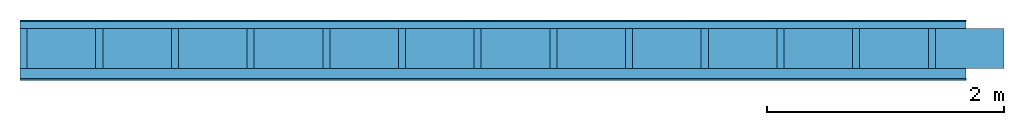
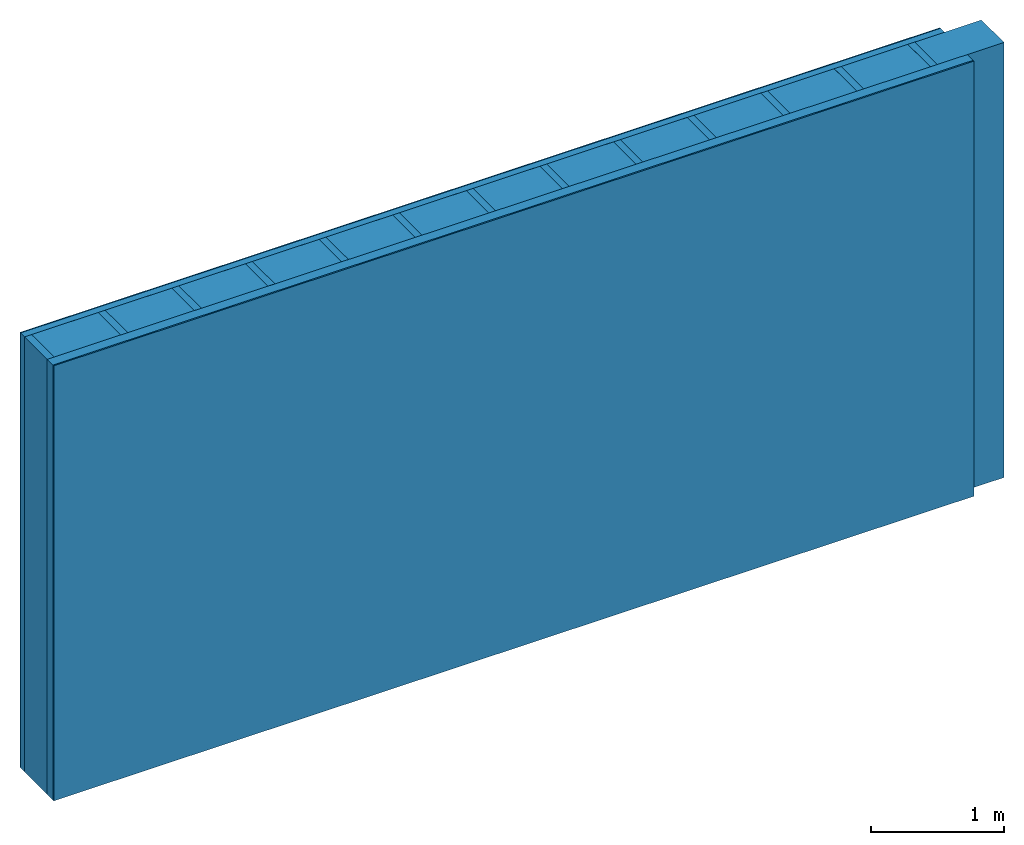
# One storey: 4 plates, 2 members, 1 element without a shape of its own.
"""IFC4 building model written with IfcOpenShell, lengths in metres."""

from ifc_helpers import new_model, si_unit, derived_unit, direction, frame, frame_2d, origin, origin_with_axes, place, context, project, spatial, rectangle, extrude, material, layer, layer_set, type_object, element, aggregate, save


model = new_model("IFC4")

# Units and contexts
plan_context = context("Plan", 3, precision=1e-05, world=origin(), true_north=direction((0.0, 1.0)))
model_context = context("Model", 3, precision=1e-05, world=origin(), true_north=direction((0.0, 1.0)))
ifc_project = project(units=[si_unit("LENGTHUNIT", "METRE"), derived_unit("SOUNDPRESSUREUNIT", [(si_unit("PRESSUREUNIT", "PASCAL", prefix="MICRO"), 0)]), si_unit("ENERGYUNIT", "JOULE", prefix="MEGA"), si_unit("MASSUNIT", "GRAM", prefix="KILO"), derived_unit("THERMALTRANSMITTANCEUNIT", [(si_unit("POWERUNIT", "WATT"), 1), (si_unit("AREAUNIT", "SQUARE_METRE"), -1), (si_unit("THERMODYNAMICTEMPERATUREUNIT", "KELVIN"), -1)]), derived_unit("AREADENSITYUNIT", [(si_unit("MASSUNIT", "GRAM", prefix="KILO"), 1), (si_unit("AREAUNIT", "SQUARE_METRE"), -1)]), derived_unit("USERDEFINED", [(si_unit("ENERGYUNIT", "JOULE", prefix="MEGA"), 1), (si_unit("AREAUNIT", "SQUARE_METRE"), -1)])], contexts=[plan_context, model_context])

# Site, building, storey
site = spatial("IfcSite", under=ifc_project)
building_placement = place(None, origin())
building = spatial("IfcBuilding", under=site, at=building_placement)
storey_placement = place(building_placement, origin())
storey = spatial("IfcBuildingStorey", under=building, at=storey_placement)

# Wall, members, plates
ifc_material_1 = material(Category="04.011")
ifc_layer_1 = layer(ifc_material_1, 0.01, Name="Surface 1")
ifc_material_2 = material(Category="10.009")
ifc_layer_2 = layer(ifc_material_2, 0.06, Name="outside 1st layer")
ifc_material_3 = material(Name="of the art")
ifc_layer_3 = layer(ifc_material_3, 0.0, Name="Bond")
ifc_layer_4 = layer(None, 0.34, Name="Support")
ifc_layer_5 = layer(ifc_material_3, 0.0, Name="Bond")
ifc_material_4 = material(Name="Solid timber panel")
ifc_layer_6 = layer(ifc_material_4, 0.087, Name="1st layer")
ifc_material_5 = material(Name="Plasterboard type A", Category="03.008")
ifc_layer_7 = layer(ifc_material_5, 0.0125, Name="Covering 1st layer")
ifc_material_6 = material(Name="joints", Category="04.017")
ifc_layer_8 = layer(ifc_material_6, 0.0, Name="Surface")
ifc_layer_set = layer_set([ifc_layer_1, ifc_layer_2, ifc_layer_3, ifc_layer_4, ifc_layer_5, ifc_layer_6, ifc_layer_7, ifc_layer_8])
wall_type = type_object("IfcWallType", Name="D0983", PredefinedType="NOTDEFINED", material=ifc_layer_set)
wall_placement = place(None, frame((0.0, 0.0, 0.0), z_axis=(0.0, -1.0, 0.0), x_axis=(1.0, 0.0, 0.0)))
wall = element("IfcWall", 1, at=wall_placement, inside=storey, type_object=wall_type, material=ifc_layer_set, Name="Wall #1")
ifc_material_7 = material()
member_1_placement = place(wall_placement, origin())
member_1 = element("IfcMember", 2, at=member_1_placement, material=ifc_material_7, Name="Support", context=plan_context, shape_type="SweptSolid", body=[
    extrude(rectangle(XDim=0.06, YDim=0.34, at=frame_2d((0.03, 0.17), x_axis=(1.0, 0.0))), frame((0.0, 4.0, 0.07), z_axis=(0.0, -1.0, 0.0), x_axis=(1.0, 0.0, 0.0)), (0.0, 0.0, 1.0), 4.0),
    extrude(rectangle(XDim=0.06, YDim=0.34, at=frame_2d((0.03, 0.17), x_axis=(1.0, 0.0))), frame((0.64, 4.0, 0.07), z_axis=(0.0, -1.0, 0.0), x_axis=(1.0, 0.0, 0.0)), (0.0, 0.0, 1.0), 4.0),
    extrude(rectangle(XDim=0.06, YDim=0.34, at=frame_2d((0.03, 0.17), x_axis=(1.0, 0.0))), frame((1.28, 4.0, 0.07), z_axis=(0.0, -1.0, 0.0), x_axis=(1.0, 0.0, 0.0)), (0.0, 0.0, 1.0), 4.0),
    extrude(rectangle(XDim=0.06, YDim=0.34, at=frame_2d((0.03, 0.17), x_axis=(1.0, 0.0))), frame((1.92, 4.0, 0.07), z_axis=(0.0, -1.0, 0.0), x_axis=(1.0, 0.0, 0.0)), (0.0, 0.0, 1.0), 4.0),
    extrude(rectangle(XDim=0.06, YDim=0.34, at=frame_2d((0.03, 0.17), x_axis=(1.0, 0.0))), frame((2.56, 4.0, 0.07), z_axis=(0.0, -1.0, 0.0), x_axis=(1.0, 0.0, 0.0)), (0.0, 0.0, 1.0), 4.0),
    extrude(rectangle(XDim=0.06, YDim=0.34, at=frame_2d((0.03, 0.17), x_axis=(1.0, 0.0))), frame((3.2, 4.0, 0.07), z_axis=(0.0, -1.0, 0.0), x_axis=(1.0, 0.0, 0.0)), (0.0, 0.0, 1.0), 4.0),
    extrude(rectangle(XDim=0.06, YDim=0.34, at=frame_2d((0.03, 0.17), x_axis=(1.0, 0.0))), frame((3.84, 4.0, 0.07), z_axis=(0.0, -1.0, 0.0), x_axis=(1.0, 0.0, 0.0)), (0.0, 0.0, 1.0), 4.0),
    extrude(rectangle(XDim=0.06, YDim=0.34, at=frame_2d((0.03, 0.17), x_axis=(1.0, 0.0))), frame((4.48, 4.0, 0.07), z_axis=(0.0, -1.0, 0.0), x_axis=(1.0, 0.0, 0.0)), (0.0, 0.0, 1.0), 4.0),
    extrude(rectangle(XDim=0.06, YDim=0.34, at=frame_2d((0.03, 0.17), x_axis=(1.0, 0.0))), frame((5.12, 4.0, 0.07), z_axis=(0.0, -1.0, 0.0), x_axis=(1.0, 0.0, 0.0)), (0.0, 0.0, 1.0), 4.0),
    extrude(rectangle(XDim=0.06, YDim=0.34, at=frame_2d((0.03, 0.17), x_axis=(1.0, 0.0))), frame((5.76, 4.0, 0.07), z_axis=(0.0, -1.0, 0.0), x_axis=(1.0, 0.0, 0.0)), (0.0, 0.0, 1.0), 4.0),
    extrude(rectangle(XDim=0.06, YDim=0.34, at=frame_2d((0.03, 0.17), x_axis=(1.0, 0.0))), frame((6.4, 4.0, 0.07), z_axis=(0.0, -1.0, 0.0), x_axis=(1.0, 0.0, 0.0)), (0.0, 0.0, 1.0), 4.0),
    extrude(rectangle(XDim=0.06, YDim=0.34, at=frame_2d((0.03, 0.17), x_axis=(1.0, 0.0))), frame((7.04, 4.0, 0.07), z_axis=(0.0, -1.0, 0.0), x_axis=(1.0, 0.0, 0.0)), (0.0, 0.0, 1.0), 4.0),
    extrude(rectangle(XDim=0.06, YDim=0.34, at=frame_2d((0.03, 0.17), x_axis=(1.0, 0.0))), frame((7.68, 4.0, 0.07), z_axis=(0.0, -1.0, 0.0), x_axis=(1.0, 0.0, 0.0)), (0.0, 0.0, 1.0), 4.0),
])
ifc_material_8 = material()
member_2_placement = place(wall_placement, origin())
member_2 = element("IfcMember", 3, at=member_2_placement, material=ifc_material_8, Name="Cavity", context=plan_context, shape_type="SweptSolid", body=[
    extrude(rectangle(XDim=0.58, YDim=0.34, at=frame_2d((0.29, 0.17), x_axis=(1.0, 0.0))), frame((0.06, 4.0, 0.07), z_axis=(0.0, -1.0, 0.0), x_axis=(1.0, 0.0, 0.0)), (0.0, 0.0, 1.0), 4.0),
    extrude(rectangle(XDim=0.58, YDim=0.34, at=frame_2d((0.29, 0.17), x_axis=(1.0, 0.0))), frame((0.7, 4.0, 0.07), z_axis=(0.0, -1.0, 0.0), x_axis=(1.0, 0.0, 0.0)), (0.0, 0.0, 1.0), 4.0),
    extrude(rectangle(XDim=0.58, YDim=0.34, at=frame_2d((0.29, 0.17), x_axis=(1.0, 0.0))), frame((1.34, 4.0, 0.07), z_axis=(0.0, -1.0, 0.0), x_axis=(1.0, 0.0, 0.0)), (0.0, 0.0, 1.0), 4.0),
    extrude(rectangle(XDim=0.58, YDim=0.34, at=frame_2d((0.29, 0.17), x_axis=(1.0, 0.0))), frame((1.98, 4.0, 0.07), z_axis=(0.0, -1.0, 0.0), x_axis=(1.0, 0.0, 0.0)), (0.0, 0.0, 1.0), 4.0),
    extrude(rectangle(XDim=0.58, YDim=0.34, at=frame_2d((0.29, 0.17), x_axis=(1.0, 0.0))), frame((2.62, 4.0, 0.07), z_axis=(0.0, -1.0, 0.0), x_axis=(1.0, 0.0, 0.0)), (0.0, 0.0, 1.0), 4.0),
    extrude(rectangle(XDim=0.58, YDim=0.34, at=frame_2d((0.29, 0.17), x_axis=(1.0, 0.0))), frame((3.26, 4.0, 0.07), z_axis=(0.0, -1.0, 0.0), x_axis=(1.0, 0.0, 0.0)), (0.0, 0.0, 1.0), 4.0),
    extrude(rectangle(XDim=0.58, YDim=0.34, at=frame_2d((0.29, 0.17), x_axis=(1.0, 0.0))), frame((3.9, 4.0, 0.07), z_axis=(0.0, -1.0, 0.0), x_axis=(1.0, 0.0, 0.0)), (0.0, 0.0, 1.0), 4.0),
    extrude(rectangle(XDim=0.58, YDim=0.34, at=frame_2d((0.29, 0.17), x_axis=(1.0, 0.0))), frame((4.54, 4.0, 0.07), z_axis=(0.0, -1.0, 0.0), x_axis=(1.0, 0.0, 0.0)), (0.0, 0.0, 1.0), 4.0),
    extrude(rectangle(XDim=0.58, YDim=0.34, at=frame_2d((0.29, 0.17), x_axis=(1.0, 0.0))), frame((5.18, 4.0, 0.07), z_axis=(0.0, -1.0, 0.0), x_axis=(1.0, 0.0, 0.0)), (0.0, 0.0, 1.0), 4.0),
    extrude(rectangle(XDim=0.58, YDim=0.34, at=frame_2d((0.29, 0.17), x_axis=(1.0, 0.0))), frame((5.82, 4.0, 0.07), z_axis=(0.0, -1.0, 0.0), x_axis=(1.0, 0.0, 0.0)), (0.0, 0.0, 1.0), 4.0),
    extrude(rectangle(XDim=0.58, YDim=0.34, at=frame_2d((0.29, 0.17), x_axis=(1.0, 0.0))), frame((6.46, 4.0, 0.07), z_axis=(0.0, -1.0, 0.0), x_axis=(1.0, 0.0, 0.0)), (0.0, 0.0, 1.0), 4.0),
    extrude(rectangle(XDim=0.58, YDim=0.34, at=frame_2d((0.29, 0.17), x_axis=(1.0, 0.0))), frame((7.1, 4.0, 0.07), z_axis=(0.0, -1.0, 0.0), x_axis=(1.0, 0.0, 0.0)), (0.0, 0.0, 1.0), 4.0),
    extrude(rectangle(XDim=0.58, YDim=0.34, at=frame_2d((0.29, 0.17), x_axis=(1.0, 0.0))), frame((7.74, 4.0, 0.07), z_axis=(0.0, -1.0, 0.0), x_axis=(1.0, 0.0, 0.0)), (0.0, 0.0, 1.0), 4.0),
])
plate_1_placement = place(wall_placement, origin())
plate_1 = element("IfcPlate", 4, at=plate_1_placement, material=ifc_material_1, Name="Surface 1", context=plan_context, shape_type="SweptSolid", body=[
    extrude(rectangle(XDim=8.0, YDim=4.0, at=frame_2d((4.0, 2.0), x_axis=(1.0, 0.0))), origin_with_axes(), (0.0, 0.0, 1.0), 0.01),
])
plate_2_placement = place(wall_placement, origin())
plate_2 = element("IfcPlate", 5, at=plate_2_placement, material=ifc_material_2, Name="outside 1st layer", context=plan_context, shape_type="SweptSolid", body=[
    extrude(rectangle(XDim=8.0, YDim=4.0, at=frame_2d((4.0, 2.0), x_axis=(1.0, 0.0))), frame((0.0, 0.0, 0.01), z_axis=(0.0, 0.0, 1.0), x_axis=(1.0, 0.0, 0.0)), (0.0, 0.0, 1.0), 0.06),
])
plate_3_placement = place(wall_placement, origin())
plate_3 = element("IfcPlate", 6, at=plate_3_placement, material=ifc_material_4, Name="1st layer", context=plan_context, shape_type="SweptSolid", body=[
    extrude(rectangle(XDim=8.0, YDim=4.0, at=frame_2d((4.0, 2.0), x_axis=(1.0, 0.0))), frame((0.0, 0.0, 0.41), z_axis=(0.0, 0.0, 1.0), x_axis=(1.0, 0.0, 0.0)), (0.0, 0.0, 1.0), 0.087),
])
plate_4_placement = place(wall_placement, origin())
plate_4 = element("IfcPlate", 7, at=plate_4_placement, material=ifc_material_5, Name="Covering 1st layer", context=plan_context, shape_type="SweptSolid", body=[
    extrude(rectangle(XDim=8.0, YDim=4.0, at=frame_2d((4.0, 2.0), x_axis=(1.0, 0.0))), frame((0.0, 0.0, 0.497), z_axis=(0.0, 0.0, 1.0), x_axis=(1.0, 0.0, 0.0)), (0.0, 0.0, 1.0), 0.0125),
])
aggregate(wall, [plate_1, plate_2, member_1, member_2, plate_3, plate_4])

save(model, "model.ifc")
